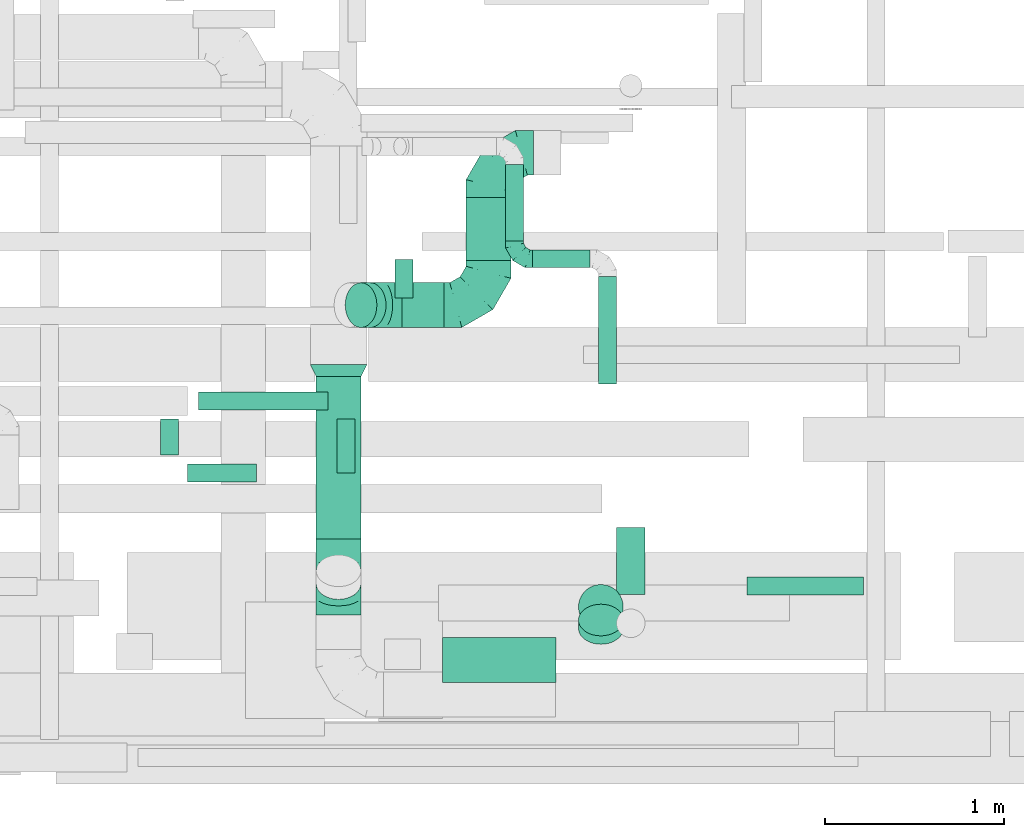
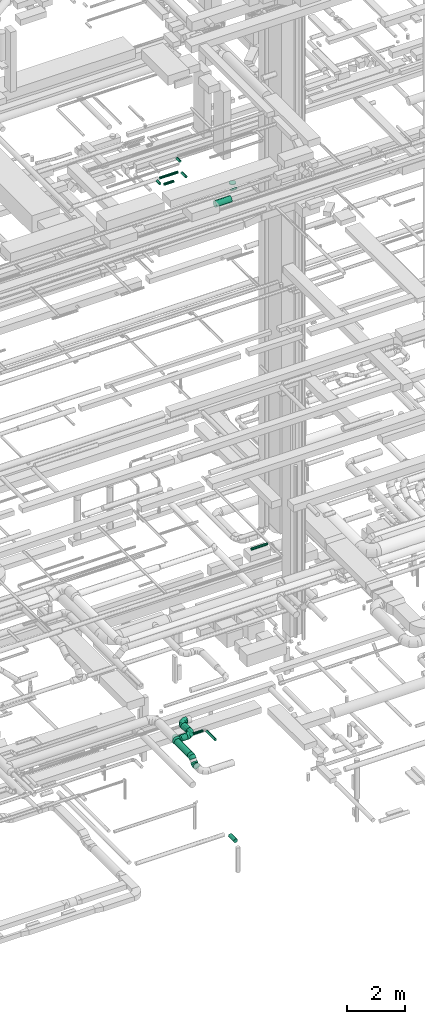
# One storey, part 123 of 337: 17 flow segments, 7 flow fittings.
"""IFC2X3 building model written with IfcOpenShell, lengths in millimetres."""

from ifc_helpers import new_model, entity, si_unit, converted_unit, derived_unit, direction, frame, origin, origin_2d_with_axis, place, context, subcontext, project, spatial, circle, extrude, faceted_brep, source, transform, mapped, material, type_object, type_shapes, element, save


model = new_model("IFC2X3")

# Units and contexts
model_context = context("Model", 3, precision=0.01, world=origin(), true_north=direction((6.12303176911189e-17, 1.0)))
body_context = subcontext(model_context, "Body", "Model", "MODEL_VIEW")
ifc_project = project(units=[si_unit("LENGTHUNIT", "METRE", prefix="MILLI"), si_unit("AREAUNIT", "SQUARE_METRE"), si_unit("VOLUMEUNIT", "CUBIC_METRE"), converted_unit("PLANEANGLEUNIT", "DEGREE", entity("IfcRatioMeasure", 0.0174532925199433), si_unit("PLANEANGLEUNIT", "RADIAN"), dimensions=[0, 0, 0, 0, 0, 0, 0]), si_unit("MASSUNIT", "GRAM", prefix="KILO"), derived_unit("MASSDENSITYUNIT", [(si_unit("MASSUNIT", "GRAM", prefix="KILO"), 1), (si_unit("LENGTHUNIT", "METRE"), -3)]), derived_unit("MOMENTOFINERTIAUNIT", [(si_unit("LENGTHUNIT", "METRE"), 4)]), si_unit("TIMEUNIT", "SECOND"), si_unit("FREQUENCYUNIT", "HERTZ"), si_unit("THERMODYNAMICTEMPERATUREUNIT", "DEGREE_CELSIUS"), derived_unit("THERMALTRANSMITTANCEUNIT", [(si_unit("MASSUNIT", "GRAM", prefix="KILO"), 1), (si_unit("THERMODYNAMICTEMPERATUREUNIT", "KELVIN"), -1), (si_unit("TIMEUNIT", "SECOND"), -3)]), derived_unit("VOLUMETRICFLOWRATEUNIT", [(si_unit("LENGTHUNIT", "METRE"), 3), (si_unit("TIMEUNIT", "SECOND"), -1)]), derived_unit("MASSFLOWRATEUNIT", [(si_unit("MASSUNIT", "GRAM", prefix="KILO"), 1), (si_unit("TIMEUNIT", "SECOND"), -1)]), derived_unit("ROTATIONALFREQUENCYUNIT", [(si_unit("TIMEUNIT", "SECOND"), -1)]), si_unit("ELECTRICCURRENTUNIT", "AMPERE"), si_unit("ELECTRICVOLTAGEUNIT", "VOLT"), si_unit("POWERUNIT", "WATT"), si_unit("FORCEUNIT", "NEWTON", prefix="KILO"), si_unit("ILLUMINANCEUNIT", "LUX"), si_unit("LUMINOUSFLUXUNIT", "LUMEN"), si_unit("LUMINOUSINTENSITYUNIT", "CANDELA"), derived_unit("USERDEFINED", [(si_unit("MASSUNIT", "GRAM", prefix="KILO"), -1), (si_unit("LENGTHUNIT", "METRE"), -2), (si_unit("TIMEUNIT", "SECOND"), 3), (si_unit("LUMINOUSFLUXUNIT", "LUMEN"), 1)]), derived_unit("LINEARVELOCITYUNIT", [(si_unit("LENGTHUNIT", "METRE"), 1), (si_unit("TIMEUNIT", "SECOND"), -1)]), si_unit("PRESSUREUNIT", "PASCAL"), derived_unit("USERDEFINED", [(si_unit("LENGTHUNIT", "METRE"), -2), (si_unit("MASSUNIT", "GRAM", prefix="KILO"), 1), (si_unit("TIMEUNIT", "SECOND"), -2)]), derived_unit("LINEARFORCEUNIT", [(si_unit("MASSUNIT", "GRAM", prefix="KILO"), 1), (si_unit("LENGTHUNIT", "METRE"), 1), (si_unit("TIMEUNIT", "SECOND"), -2), (si_unit("LENGTHUNIT", "METRE"), -1)]), derived_unit("PLANARFORCEUNIT", [(si_unit("MASSUNIT", "GRAM", prefix="KILO"), 1), (si_unit("LENGTHUNIT", "METRE"), 1), (si_unit("TIMEUNIT", "SECOND"), -2), (si_unit("LENGTHUNIT", "METRE"), -2)])], contexts=[model_context])

# Site, building, storey
site_placement = place(None, origin())
site = spatial("IfcSite", under=ifc_project, at=site_placement, CompositionType="ELEMENT")
building_placement = place(site_placement, origin())
building = spatial("IfcBuilding", under=site, at=building_placement, CompositionType="ELEMENT")
storey_placement = place(building_placement, origin())
storey = spatial("IfcBuildingStorey", under=building, at=storey_placement, CompositionType="ELEMENT", Elevation=0.0)

# Flow segments
duct_segment_type = type_object("IfcDuctSegmentType", PredefinedType="NOTDEFINED")
flow_segment_1_placement = place(storey_placement, frame((37082.67, 1408.64, -681.6)))
element("IfcFlowSegment", 1, at=flow_segment_1_placement, inside=storey, type_object=duct_segment_type, context=body_context, shape_type="SweptSolid", body=[
    extrude(circle(Radius=80.0, at=origin_2d_with_axis()), frame((81.6, 0.0, 81.6), z_axis=(0.0, 1.0, 0.0), x_axis=(-1.0, 0.0, 0.0)), (0.0, 0.0, 1.0), 375.627069999998),
])
flow_segment_2_placement = place(storey_placement, frame((37812.77, 1406.28, 11418.4)))
element("IfcFlowSegment", 2, at=flow_segment_2_placement, inside=storey, type_object=duct_segment_type, context=body_context, shape_type="SweptSolid", body=[
    extrude(circle(Radius=50.0, at=origin_2d_with_axis()), frame((0.0, 51.6, 51.6), z_axis=(1.0, 0.0, 0.0), x_axis=(0.0, 1.0, 0.0)), (0.0, 0.0, 1.0), 649.999999999982),
])
flow_segment_3_placement = place(storey_placement, frame((35406.66, 1718.56, 3290.9)))
element("IfcFlowSegment", 3, at=flow_segment_3_placement, inside=storey, type_object=duct_segment_type, context=body_context, shape_type="SweptSolid", body=[
    extrude(circle(Radius=125.0, at=origin_2d_with_axis()), frame((126.6, 0.0, 126.6), z_axis=(0.0, 1.0, 0.0), x_axis=(1.0, 0.0, 0.0)), (0.0, 0.0, 1.0), 908.226588789916),
])
flow_segment_4_placement = place(storey_placement, frame((36244.07, 3274.61, 3073.4)))
element("IfcFlowSegment", 4, at=flow_segment_4_placement, inside=storey, type_object=duct_segment_type, context=body_context, shape_type="SweptSolid", body=[
    extrude(circle(Radius=125.0, at=origin_2d_with_axis()), frame((126.6, 0.0, 126.6), z_axis=(0.0, 1.0, 0.0), x_axis=(1.0, 0.0, 0.0)), (0.0, 0.0, 1.0), 350.000000000023),
])
flow_segment_5_placement = place(storey_placement, frame((35886.72, 2898.01, 3073.4)))
element("IfcFlowSegment", 5, at=flow_segment_5_placement, inside=storey, type_object=duct_segment_type, context=body_context, shape_type="SweptSolid", body=[
    extrude(circle(Radius=125.0, at=origin_2d_with_axis()), frame((0.0, 126.6, 126.6), z_axis=(1.0, 0.0, 0.0), x_axis=(0.0, 1.0, 0.0)), (0.0, 0.0, 1.0), 233.946609406771),
])
flow_segment_6_placement = place(storey_placement, frame((35568.74, 2898.01, 3183.24)))
element("IfcFlowSegment", 6, at=flow_segment_6_placement, inside=storey, type_object=duct_segment_type, context=body_context, shape_type="SweptSolid", body=[
    extrude(circle(Radius=125.0, at=origin_2d_with_axis()), frame((141.2, 126.6, 89.98), z_axis=(-0.707106781186511, 0.0, 0.707106781186584), x_axis=(0.0, -1.0, 0.0)), (0.0, 0.0, 1.0), 72.4322018853767),
])
flow_segment_7_placement = place(storey_placement, frame((36463.89, 3383.31, 2948.4)))
element("IfcFlowSegment", 7, at=flow_segment_7_placement, inside=storey, type_object=duct_segment_type, context=body_context, shape_type="SweptSolid", body=[
    extrude(circle(Radius=50.0, at=origin_2d_with_axis()), frame((51.6, 0.0, 51.6), z_axis=(0.0, 1.0, 0.0), x_axis=(-1.0, 0.0, 0.0)), (0.0, 0.0, 1.0), 426.250000000013),
])
flow_segment_8_placement = place(storey_placement, frame((36615.48, 3231.71, 2948.4)))
element("IfcFlowSegment", 8, at=flow_segment_8_placement, inside=storey, type_object=duct_segment_type, context=body_context, shape_type="SweptSolid", body=[
    extrude(circle(Radius=50.0, at=origin_2d_with_axis()), frame((0.0, 51.6, 51.6), z_axis=(1.0, 0.0, 0.0), x_axis=(0.0, -1.0, 0.0)), (0.0, 0.0, 1.0), 320.000000000001),
])
flow_segment_9_placement = place(storey_placement, frame((36983.89, 2583.31, 2948.4)))
element("IfcFlowSegment", 9, at=flow_segment_9_placement, inside=storey, type_object=duct_segment_type, context=body_context, shape_type="SweptSolid", body=[
    extrude(circle(Radius=50.0, at=origin_2d_with_axis()), frame((51.6, 0.0, 51.6), z_axis=(0.0, 1.0, 0.0), x_axis=(-1.0, 0.0, 0.0)), (0.0, 0.0, 1.0), 599.999999999995),
])
flow_segment_10_placement = place(storey_placement, frame((35846.88, 3065.24, 27498.4)))
element("IfcFlowSegment", 10, at=flow_segment_10_placement, inside=storey, type_object=duct_segment_type, context=body_context, shape_type="SweptSolid", body=[
    extrude(circle(Radius=50.0, at=origin_2d_with_axis()), frame((51.6, 0.0, 51.6), z_axis=(0.0, 1.0, 0.0), x_axis=(-1.0, 0.0, 0.0)), (0.0, 0.0, 1.0), 214.999999999988),
])
flow_segment_11_placement = place(storey_placement, frame((35523.91, 2087.55, 27548.4)))
element("IfcFlowSegment", 11, at=flow_segment_11_placement, inside=storey, type_object=duct_segment_type, context=body_context, shape_type="SweptSolid", body=[
    extrude(circle(Radius=50.0, at=origin_2d_with_axis()), frame((51.6, 0.0, 51.6), z_axis=(0.0, 1.0, 0.0), x_axis=(-1.0, 0.0, 0.0)), (0.0, 0.0, 1.0), 301.519488620757),
])
flow_segment_12_placement = place(storey_placement, frame((34538.3, 2187.55, 27548.4)))
element("IfcFlowSegment", 12, at=flow_segment_12_placement, inside=storey, type_object=duct_segment_type, context=body_context, shape_type="SweptSolid", body=[
    extrude(circle(Radius=50.0, at=origin_2d_with_axis()), frame((51.6, 0.0, 51.6), z_axis=(0.0, 1.0, 0.0), x_axis=(1.0, 0.0, 0.0)), (0.0, 0.0, 1.0), 201.519488620777),
])
flow_segment_13_placement = place(storey_placement, frame((34689.9, 2035.95, 27548.4)))
element("IfcFlowSegment", 13, at=flow_segment_13_placement, inside=storey, type_object=duct_segment_type, context=body_context, shape_type="SweptSolid", body=[
    extrude(circle(Radius=50.0, at=origin_2d_with_axis()), frame((0.0, 51.6, 51.6), z_axis=(1.0, 0.0, 0.0), x_axis=(0.0, -1.0, 0.0)), (0.0, 0.0, 1.0), 386.249999999973),
])
flow_segment_14_placement = place(storey_placement, frame((34750.5, 2437.47, 27548.4)))
element("IfcFlowSegment", 14, at=flow_segment_14_placement, inside=storey, type_object=duct_segment_type, context=body_context, shape_type="SweptSolid", body=[
    extrude(circle(Radius=50.0, at=origin_2d_with_axis()), frame((0.0, 51.6, 51.6), z_axis=(1.0, 0.0, 0.0), x_axis=(0.0, -1.0, 0.0)), (0.0, 0.0, 1.0), 725.0),
])
flow_segment_15_placement = place(storey_placement, frame((36114.8, 916.58, 26773.4)))
element("IfcFlowSegment", 15, at=flow_segment_15_placement, inside=storey, type_object=duct_segment_type, context=body_context, shape_type="SweptSolid", body=[
    extrude(circle(Radius=125.0, at=origin_2d_with_axis()), frame((0.0, 126.6, 126.6), z_axis=(1.0, 0.0, 0.0), x_axis=(0.0, -1.0, 0.0)), (0.0, 0.0, 1.0), 632.499999999999),
])
flow_segment_16_placement = place(storey_placement, frame((36870.71, 1129.97, 26986.79)))
element("IfcFlowSegment", 16, at=flow_segment_16_placement, inside=storey, type_object=duct_segment_type, context=body_context, shape_type="SweptSolid", body=[
    extrude(circle(Radius=125.0, at=origin_2d_with_axis()), frame((126.6, 89.98, 89.98), z_axis=(0.0, 0.707106781186545, 0.70710678118655), x_axis=(1.0, 0.0, 0.0)), (0.0, 0.0, 1.0), 66.4466094067439),
])
flow_segment_17_placement = place(storey_placement, frame((36870.71, 1213.56, 27300.54)))
element("IfcFlowSegment", 17, at=flow_segment_17_placement, inside=storey, type_object=duct_segment_type, context=body_context, shape_type="SweptSolid", body=[
    extrude(circle(Radius=125.0, at=origin_2d_with_axis()), frame((126.6, 126.6, 0.0), z_axis=(0.0, 0.0, 1.0), x_axis=(0.0, 1.0, 0.0)), (0.0, 0.0, 1.0), 29.4617613084081),
])

# Flow fittings
ifc_material = material()
duct_fitting_type_1 = type_object("IfcDuctFittingType", PredefinedType="NOTDEFINED", material=ifc_material)
shared_shape_1 = source(origin(), body_context, "Body", "Brep", [
    faceted_brep([(-100.0, 0.0, -50.0), (-100.0, -12.94, -48.3), (-100.0, -25.0, -43.3), (-100.0, -35.36, -35.36), (-100.0, -43.3, -25.0), (-100.0, -48.3, -12.94), (-100.0, -50.0, 0.0), (-100.0, -48.3, 12.94), (-100.0, -43.3, 25.0), (-100.0, -35.36, 35.36), (-100.0, -25.0, 43.3), (-100.0, -12.94, 48.3), (-100.0, 0.0, 50.0), (-100.0, 12.94, 48.3), (-100.0, 25.0, 43.3), (-100.0, 35.36, 35.36), (-100.0, 43.3, 25.0), (-100.0, 48.3, 12.94), (-100.0, 50.0, 0.0), (-100.0, 48.3, -12.94), (-100.0, 43.3, -25.0), (-100.0, 35.36, -35.36), (-100.0, 25.0, -43.3), (-100.0, 12.94, -48.3), (-76.67, 12.94, 48.3), (-79.9, 25.0, 43.3), (-73.21, 0.0, 50.0), (-82.68, 35.36, 35.36), (-86.15, 48.3, 12.94), (-86.6, 50.0, 0.0), (-84.81, 43.3, 25.0), (-84.81, 43.3, -25.0), (-82.68, 35.36, -35.36), (-86.15, 48.3, -12.94), (-76.67, 12.94, -48.3), (-73.21, 0.0, -50.0), (-79.9, 25.0, -43.3), (-69.74, -12.94, -48.3), (-66.51, -25.0, -43.3), (-63.73, -35.36, -35.36), (-61.6, -43.3, -25.0), (-60.26, -48.3, -12.94), (-59.81, -50.0, 0.0), (-60.26, -48.3, 12.94), (-61.6, -43.3, 25.0), (-63.73, -35.36, 35.36), (-66.51, -25.0, 43.3), (-69.74, -12.94, 48.3), (-36.27, 36.27, 48.3), (-45.1, 45.1, 43.3), (-26.79, 26.79, 50.0), (-52.68, 52.68, 35.36), (-58.49, 58.49, 25.0), (-62.15, 62.15, 12.94), (-63.4, 63.4, 0.0), (-62.15, 62.15, -12.94), (-58.49, 58.49, -25.0), (-52.68, 52.68, -35.36), (-36.27, 36.27, -48.3), (-26.79, 26.79, -50.0), (-45.1, 45.1, -43.3), (-17.32, 17.32, -48.3), (-8.49, 8.49, -43.3), (-0.91, 0.91, -35.36), (4.9, -4.9, -25.0), (8.56, -8.56, -12.94), (9.81, -9.81, 0.0), (8.56, -8.56, 12.94), (4.9, -4.9, 25.0), (-0.91, 0.91, 35.36), (-8.49, 8.49, 43.3), (-17.32, 17.32, 48.3), (-12.94, 76.67, 48.3), (-25.0, 79.9, 43.3), (0.0, 73.21, 50.0), (-35.36, 82.68, 35.36), (-43.3, 84.81, 25.0), (-48.3, 86.15, 12.94), (-50.0, 86.6, 0.0), (-48.3, 86.15, -12.94), (-43.3, 84.81, -25.0), (-35.36, 82.68, -35.36), (-12.94, 76.67, -48.3), (0.0, 73.21, -50.0), (-25.0, 79.9, -43.3), (12.94, 69.74, -48.3), (25.0, 66.51, -43.3), (35.36, 63.73, -35.36), (43.3, 61.6, -25.0), (48.3, 60.26, -12.94), (50.0, 59.81, 0.0), (48.3, 60.26, 12.94), (43.3, 61.6, 25.0), (35.36, 63.73, 35.36), (25.0, 66.51, 43.3), (12.94, 69.74, 48.3), (-12.94, 100.0, -48.3), (-25.0, 100.0, -43.3), (-35.36, 100.0, -35.36), (-43.3, 100.0, -25.0), (-48.3, 100.0, -12.94), (-50.0, 100.0, 0.0), (-48.3, 100.0, 12.94), (-43.3, 100.0, 25.0), (-35.36, 100.0, 35.36), (-25.0, 100.0, 43.3), (-12.94, 100.0, 48.3), (0.0, 100.0, 50.0), (12.94, 100.0, 48.3), (25.0, 100.0, 43.3), (35.36, 100.0, 35.36), (43.3, 100.0, 25.0), (48.3, 100.0, 12.94), (50.0, 100.0, 0.0), (48.3, 100.0, -12.94), (43.3, 100.0, -25.0), (35.36, 100.0, -35.36), (25.0, 100.0, -43.3), (12.94, 100.0, -48.3), (0.0, 100.0, -50.0)], [[[0, 1, 2, 3, 4, 5, 6, 7, 8, 9, 10, 11, 12, 13, 14, 15, 16, 17, 18, 19, 20, 21, 22, 23]], [[24, 25, 14, 13]], [[26, 24, 13, 12]], [[14, 25, 27, 15]], [[28, 29, 18, 17]], [[30, 28, 17, 16]], [[15, 27, 30, 16]], [[20, 31, 32, 21]], [[33, 31, 20, 19]], [[18, 29, 33, 19]], [[34, 35, 0, 23]], [[36, 34, 23, 22]], [[32, 36, 22, 21]], [[2, 1, 37, 38]], [[3, 2, 38, 39]], [[0, 35, 37, 1]], [[5, 4, 40, 41]], [[6, 5, 41, 42]], [[3, 39, 40, 4]], [[6, 42, 43, 7]], [[7, 43, 44, 8]], [[8, 44, 45, 9]], [[10, 46, 47, 11]], [[11, 47, 26, 12]], [[10, 9, 45, 46]], [[48, 49, 25, 24]], [[50, 48, 24, 26]], [[27, 25, 49, 51]], [[52, 53, 28, 30]], [[51, 52, 30, 27]], [[29, 28, 53, 54]], [[55, 56, 31, 33]], [[54, 55, 33, 29]], [[57, 32, 31, 56]], [[58, 59, 35, 34]], [[60, 58, 34, 36]], [[57, 60, 36, 32]], [[37, 35, 59, 61]], [[38, 37, 61, 62]], [[39, 38, 62, 63]], [[41, 40, 64, 65]], [[42, 41, 65, 66]], [[63, 64, 40, 39]], [[43, 42, 66, 67]], [[44, 43, 67, 68]], [[68, 69, 45, 44]], [[46, 45, 69, 70]], [[47, 46, 70, 71]], [[26, 47, 71, 50]], [[72, 73, 49, 48]], [[74, 72, 48, 50]], [[51, 49, 73, 75]], [[76, 77, 53, 52]], [[75, 76, 52, 51]], [[54, 53, 77, 78]], [[79, 80, 56, 55]], [[78, 79, 55, 54]], [[81, 57, 56, 80]], [[82, 83, 59, 58]], [[84, 82, 58, 60]], [[81, 84, 60, 57]], [[61, 59, 83, 85]], [[62, 61, 85, 86]], [[63, 62, 86, 87]], [[65, 64, 88, 89]], [[66, 65, 89, 90]], [[87, 88, 64, 63]], [[67, 66, 90, 91]], [[68, 67, 91, 92]], [[92, 93, 69, 68]], [[70, 69, 93, 94]], [[71, 70, 94, 95]], [[50, 71, 95, 74]], [[96, 97, 98, 99, 100, 101, 102, 103, 104, 105, 106, 107, 108, 109, 110, 111, 112, 113, 114, 115, 116, 117, 118, 119]], [[72, 74, 107, 106]], [[73, 72, 106, 105]], [[75, 73, 105, 104]], [[77, 76, 103, 102]], [[78, 77, 102, 101]], [[75, 104, 103, 76]], [[78, 101, 100, 79]], [[79, 100, 99, 80]], [[80, 99, 98, 81]], [[96, 119, 83, 82]], [[97, 96, 82, 84]], [[84, 81, 98, 97]], [[83, 119, 118, 85]], [[85, 118, 117, 86]], [[86, 117, 116, 87]], [[88, 115, 114, 89]], [[89, 114, 113, 90]], [[87, 116, 115, 88]], [[91, 90, 113, 112]], [[92, 91, 112, 111]], [[93, 92, 111, 110]], [[95, 94, 109, 108]], [[74, 95, 108, 107]], [[110, 109, 94, 93]]]),
])
type_shapes(duct_fitting_type_1, [shared_shape_1])
flow_fitting_1_placement = place(storey_placement, frame((36515.48, 3283.31, 3000.0), z_axis=(0.0, 0.0, 1.0), x_axis=(0.0, -1.0, 0.0)))
element("IfcFlowFitting", 18, at=flow_fitting_1_placement, inside=storey, type_object=duct_fitting_type_1, material=ifc_material, context=body_context, shape_type="MappedRepresentation", body=[
    mapped(shared_shape_1, transform((0.0, 0.0, 0.0), scale=1.0)),
])
duct_fitting_type_2 = type_object("IfcDuctFittingType", PredefinedType="NOTDEFINED", material=ifc_material)
shared_shape_2 = source(origin(), body_context, "Body", "Brep", [
    faceted_brep([(-250.0, 0.0, -125.0), (-250.0, -32.35, -120.74), (-250.0, -62.5, -108.25), (-250.0, -88.39, -88.39), (-250.0, -108.25, -62.5), (-250.0, -120.74, -32.35), (-250.0, -125.0, 0.0), (-250.0, -120.74, 32.35), (-250.0, -108.25, 62.5), (-250.0, -88.39, 88.39), (-250.0, -62.5, 108.25), (-250.0, -32.35, 120.74), (-250.0, 0.0, 125.0), (-250.0, 32.35, 120.74), (-250.0, 62.5, 108.25), (-250.0, 88.39, 88.39), (-250.0, 108.25, 62.5), (-250.0, 120.74, 32.35), (-250.0, 125.0, 0.0), (-250.0, 120.74, -32.35), (-250.0, 108.25, -62.5), (-250.0, 88.39, -88.39), (-250.0, 62.5, -108.25), (-250.0, 32.35, -120.74), (-191.68, 32.35, 120.74), (-199.76, 62.5, 108.25), (-183.01, 0.0, 125.0), (-206.7, 88.39, 88.39), (-215.37, 120.74, 32.35), (-216.51, 125.0, 0.0), (-212.02, 108.25, 62.5), (-212.02, 108.25, -62.5), (-206.7, 88.39, -88.39), (-215.37, 120.74, -32.35), (-191.68, 32.35, -120.74), (-183.01, 0.0, -125.0), (-199.76, 62.5, -108.25), (-174.34, -32.35, -120.74), (-166.27, -62.5, -108.25), (-159.33, -88.39, -88.39), (-154.01, -108.25, -62.5), (-150.66, -120.74, -32.35), (-149.52, -125.0, 0.0), (-150.66, -120.74, 32.35), (-154.01, -108.25, 62.5), (-159.33, -88.39, 88.39), (-166.27, -62.5, 108.25), (-174.34, -32.35, 120.74), (-90.67, 90.67, 120.74), (-112.74, 112.74, 108.25), (-66.99, 66.99, 125.0), (-131.69, 131.69, 88.39), (-146.23, 146.23, 62.5), (-155.38, 155.38, 32.35), (-158.49, 158.49, 0.0), (-155.38, 155.38, -32.35), (-146.23, 146.23, -62.5), (-131.69, 131.69, -88.39), (-90.67, 90.67, -120.74), (-66.99, 66.99, -125.0), (-112.74, 112.74, -108.25), (-43.3, 43.3, -120.74), (-21.23, 21.23, -108.25), (-2.28, 2.28, -88.39), (12.26, -12.26, -62.5), (21.4, -21.4, -32.35), (24.52, -24.52, 0.0), (21.4, -21.4, 32.35), (12.26, -12.26, 62.5), (-2.28, 2.28, 88.39), (-21.23, 21.23, 108.25), (-43.3, 43.3, 120.74), (-32.35, 191.68, 120.74), (-62.5, 199.76, 108.25), (0.0, 183.01, 125.0), (-88.39, 206.7, 88.39), (-108.25, 212.02, 62.5), (-120.74, 215.37, 32.35), (-125.0, 216.51, 0.0), (-120.74, 215.37, -32.35), (-108.25, 212.02, -62.5), (-88.39, 206.7, -88.39), (-32.35, 191.68, -120.74), (0.0, 183.01, -125.0), (-62.5, 199.76, -108.25), (32.35, 174.34, -120.74), (62.5, 166.27, -108.25), (88.39, 159.33, -88.39), (108.25, 154.01, -62.5), (120.74, 150.66, -32.35), (125.0, 149.52, 0.0), (120.74, 150.66, 32.35), (108.25, 154.01, 62.5), (88.39, 159.33, 88.39), (62.5, 166.27, 108.25), (32.35, 174.34, 120.74), (-32.35, 250.0, -120.74), (-62.5, 250.0, -108.25), (-88.39, 250.0, -88.39), (-108.25, 250.0, -62.5), (-120.74, 250.0, -32.35), (-125.0, 250.0, 0.0), (-120.74, 250.0, 32.35), (-108.25, 250.0, 62.5), (-88.39, 250.0, 88.39), (-62.5, 250.0, 108.25), (-32.35, 250.0, 120.74), (0.0, 250.0, 125.0), (32.35, 250.0, 120.74), (62.5, 250.0, 108.25), (88.39, 250.0, 88.39), (108.25, 250.0, 62.5), (120.74, 250.0, 32.35), (125.0, 250.0, 0.0), (120.74, 250.0, -32.35), (108.25, 250.0, -62.5), (88.39, 250.0, -88.39), (62.5, 250.0, -108.25), (32.35, 250.0, -120.74), (0.0, 250.0, -125.0)], [[[0, 1, 2, 3, 4, 5, 6, 7, 8, 9, 10, 11, 12, 13, 14, 15, 16, 17, 18, 19, 20, 21, 22, 23]], [[24, 25, 14, 13]], [[26, 24, 13, 12]], [[14, 25, 27, 15]], [[28, 29, 18, 17]], [[30, 28, 17, 16]], [[15, 27, 30, 16]], [[20, 31, 32, 21]], [[33, 31, 20, 19]], [[18, 29, 33, 19]], [[34, 35, 0, 23]], [[36, 34, 23, 22]], [[21, 32, 36, 22]], [[1, 0, 35, 37]], [[2, 1, 37, 38]], [[38, 39, 3, 2]], [[5, 4, 40, 41]], [[6, 5, 41, 42]], [[39, 40, 4, 3]], [[6, 42, 43, 7]], [[7, 43, 44, 8]], [[8, 44, 45, 9]], [[9, 45, 46, 10]], [[10, 46, 47, 11]], [[26, 12, 11, 47]], [[48, 49, 25, 24]], [[50, 48, 24, 26]], [[27, 25, 49, 51]], [[52, 53, 28, 30]], [[51, 52, 30, 27]], [[29, 28, 53, 54]], [[55, 56, 31, 33]], [[54, 55, 33, 29]], [[32, 31, 56, 57]], [[58, 59, 35, 34]], [[60, 58, 34, 36]], [[57, 60, 36, 32]], [[37, 35, 59, 61]], [[38, 37, 61, 62]], [[39, 38, 62, 63]], [[41, 40, 64, 65]], [[42, 41, 65, 66]], [[63, 64, 40, 39]], [[43, 42, 66, 67]], [[44, 43, 67, 68]], [[68, 69, 45, 44]], [[46, 45, 69, 70]], [[47, 46, 70, 71]], [[26, 47, 71, 50]], [[72, 73, 49, 48]], [[74, 72, 48, 50]], [[51, 49, 73, 75]], [[76, 77, 53, 52]], [[75, 76, 52, 51]], [[54, 53, 77, 78]], [[79, 80, 56, 55]], [[78, 79, 55, 54]], [[57, 56, 80, 81]], [[82, 83, 59, 58]], [[84, 82, 58, 60]], [[81, 84, 60, 57]], [[61, 59, 83, 85]], [[62, 61, 85, 86]], [[63, 62, 86, 87]], [[65, 64, 88, 89]], [[66, 65, 89, 90]], [[87, 88, 64, 63]], [[67, 66, 90, 91]], [[68, 67, 91, 92]], [[92, 93, 69, 68]], [[70, 69, 93, 94]], [[71, 70, 94, 95]], [[50, 71, 95, 74]], [[96, 97, 98, 99, 100, 101, 102, 103, 104, 105, 106, 107, 108, 109, 110, 111, 112, 113, 114, 115, 116, 117, 118, 119]], [[72, 74, 107, 106]], [[73, 72, 106, 105]], [[75, 73, 105, 104]], [[77, 76, 103, 102]], [[78, 77, 102, 101]], [[75, 104, 103, 76]], [[78, 101, 100, 79]], [[79, 100, 99, 80]], [[80, 99, 98, 81]], [[84, 97, 96, 82]], [[82, 96, 119, 83]], [[84, 81, 98, 97]], [[83, 119, 118, 85]], [[85, 118, 117, 86]], [[116, 87, 86, 117]], [[88, 115, 114, 89]], [[89, 114, 113, 90]], [[115, 88, 87, 116]], [[91, 90, 113, 112]], [[92, 91, 112, 111]], [[111, 110, 93, 92]], [[95, 94, 109, 108]], [[74, 95, 108, 107]], [[110, 109, 94, 93]]]),
])
type_shapes(duct_fitting_type_2, [shared_shape_2])
flow_fitting_2_placement = place(storey_placement, frame((36370.66, 3874.61, 3200.0), z_axis=(0.0, 0.0, 1.0), x_axis=(-1.0, 0.0, 0.0)))
element("IfcFlowFitting", 19, at=flow_fitting_2_placement, inside=storey, type_object=duct_fitting_type_2, material=ifc_material, context=body_context, shape_type="MappedRepresentation", body=[
    mapped(shared_shape_2, transform((0.0, 0.0, 0.0), scale=1.0)),
])
flow_fitting_3_placement = place(storey_placement, frame((36370.66, 3024.61, 3200.0)))
element("IfcFlowFitting", 20, at=flow_fitting_3_placement, inside=storey, type_object=duct_fitting_type_2, material=ifc_material, context=body_context, shape_type="MappedRepresentation", body=[
    mapped(shared_shape_2, transform((0.0, 0.0, 0.0), scale=1.0)),
])
duct_fitting_type_3 = type_object("IfcDuctFittingType", PredefinedType="NOTDEFINED", material=ifc_material)
shared_shape_3 = source(origin(), body_context, "Body", "Brep", [
    faceted_brep([(-103.55, 0.0, -125.0), (-103.55, -32.35, -120.74), (-103.55, -62.5, -108.25), (-103.55, -88.39, -88.39), (-103.55, -108.25, -62.5), (-103.55, -120.74, -32.35), (-103.55, -125.0, 0.0), (-103.55, -120.74, 32.35), (-103.55, -108.25, 62.5), (-103.55, -88.39, 88.39), (-103.55, -62.5, 108.25), (-103.55, -32.35, 120.74), (-103.55, 0.0, 125.0), (-103.55, 32.35, 120.74), (-103.55, 62.5, 108.25), (-103.55, 88.39, 88.39), (-103.55, 108.25, 62.5), (-103.55, 120.74, 32.35), (-103.55, 125.0, 0.0), (-103.55, 120.74, -32.35), (-103.55, 108.25, -62.5), (-103.55, 88.39, -88.39), (-103.55, 62.5, -108.25), (-103.55, 32.35, -120.74), (-13.4, 32.35, 120.74), (-25.89, 62.5, 108.25), (0.0, 0.0, 125.0), (-36.61, 88.39, 88.39), (-44.84, 108.25, 62.5), (-50.01, 120.74, 32.35), (-51.78, 125.0, 0.0), (-50.01, 120.74, -32.35), (-44.84, 108.25, -62.5), (-36.61, 88.39, -88.39), (-13.4, 32.35, -120.74), (0.0, 0.0, -125.0), (-25.89, 62.5, -108.25), (13.4, -32.35, -120.74), (25.89, -62.5, -108.25), (36.61, -88.39, -88.39), (44.84, -108.25, -62.5), (50.01, -120.74, -32.35), (51.78, -125.0, 0.0), (50.01, -120.74, 32.35), (44.84, -108.25, 62.5), (36.61, -88.39, 88.39), (25.89, -62.5, 108.25), (13.4, -32.35, 120.74), (73.22, 73.22, 125.0), (50.35, 96.1, 120.74), (29.03, 117.42, 108.25), (10.72, 135.72, 88.39), (-3.32, 149.77, 62.5), (-12.15, 158.6, 32.35), (-15.17, 161.61, 0.0), (-12.15, 158.6, -32.35), (-3.32, 149.77, -62.5), (10.72, 135.72, -88.39), (29.03, 117.42, -108.25), (50.35, 96.1, -120.74), (73.22, 73.22, -125.0), (96.1, 50.35, -120.74), (117.42, 29.03, -108.25), (135.72, 10.72, -88.39), (149.77, -3.32, -62.5), (158.6, -12.15, -32.35), (161.61, -15.17, 0.0), (158.6, -12.15, 32.35), (149.77, -3.32, 62.5), (135.72, 10.72, 88.39), (117.42, 29.03, 108.25), (96.1, 50.35, 120.74)], [[[0, 1, 2, 3, 4, 5, 6, 7, 8, 9, 10, 11, 12, 13, 14, 15, 16, 17, 18, 19, 20, 21, 22, 23]], [[24, 25, 14, 13]], [[26, 24, 13, 12]], [[14, 25, 27, 15]], [[28, 29, 17, 16]], [[28, 16, 15, 27]], [[30, 18, 17, 29]], [[31, 32, 20, 19]], [[30, 31, 19, 18]], [[32, 33, 21, 20]], [[34, 35, 0, 23]], [[36, 34, 23, 22]], [[33, 36, 22, 21]], [[1, 0, 35, 37]], [[2, 1, 37, 38]], [[38, 39, 3, 2]], [[5, 4, 40, 41]], [[6, 5, 41, 42]], [[39, 40, 4, 3]], [[6, 42, 43, 7]], [[7, 43, 44, 8]], [[8, 44, 45, 9]], [[9, 45, 46, 10]], [[10, 46, 47, 11]], [[26, 12, 11, 47]], [[24, 26, 48, 49]], [[25, 24, 49, 50]], [[27, 25, 50, 51]], [[29, 28, 52, 53]], [[30, 29, 53, 54]], [[51, 52, 28, 27]], [[30, 54, 55, 31]], [[31, 55, 56, 32]], [[57, 33, 32, 56]], [[36, 58, 59, 34]], [[34, 59, 60, 35]], [[58, 36, 33, 57]], [[35, 60, 61, 37]], [[37, 61, 62, 38]], [[63, 39, 38, 62]], [[40, 64, 65, 41]], [[41, 65, 66, 42]], [[64, 40, 39, 63]], [[43, 42, 66, 67]], [[44, 43, 67, 68]], [[68, 69, 45, 44]], [[47, 46, 70, 71]], [[26, 47, 71, 48]], [[69, 70, 46, 45]], [[59, 58, 57, 56, 55, 54, 53, 52, 51, 50, 49, 48, 71, 70, 69, 68, 67, 66, 65, 64, 63, 62, 61, 60]]]),
])
type_shapes(duct_fitting_type_3, [shared_shape_3])
flow_fitting_4_placement = place(storey_placement, frame((35533.26, 1397.51, 3200.0), z_axis=(1.0, 0.0, 0.0), x_axis=(0.0, 1.0, 0.0)))
element("IfcFlowFitting", 21, at=flow_fitting_4_placement, inside=storey, type_object=duct_fitting_type_3, material=ifc_material, context=body_context, shape_type="MappedRepresentation", body=[
    mapped(shared_shape_3, transform((0.0, 0.0, 0.0), scale=1.0)),
])
duct_fitting_type_4 = type_object("IfcDuctFittingType", PredefinedType="NOTDEFINED", material=ifc_material)
type_shapes(duct_fitting_type_4, [shared_shape_3])
flow_fitting_5_placement = place(storey_placement, frame((35783.16, 3024.61, 3200.0), z_axis=(0.0, 1.0, 0.0), x_axis=(-1.0, 0.0, 0.0)))
element("IfcFlowFitting", 22, at=flow_fitting_5_placement, inside=storey, type_object=duct_fitting_type_4, material=ifc_material, context=body_context, shape_type="MappedRepresentation", body=[
    mapped(shared_shape_3, transform((0.0, 0.0, 0.0), scale=1.0)),
])
flow_fitting_6_placement = place(storey_placement, frame((35533.26, 1615.01, 3417.5), z_axis=(-1.0, 0.0, 0.0), x_axis=(0.0, 0.707106792500146, 0.707106769872949)))
element("IfcFlowFitting", 23, at=flow_fitting_6_placement, inside=storey, type_object=duct_fitting_type_3, material=ifc_material, context=body_context, shape_type="MappedRepresentation", body=[
    mapped(shared_shape_3, transform((0.0, 0.0, 0.0), scale=1.0)),
])
duct_fitting_type_5 = type_object("IfcDuctFittingType", PredefinedType="NOTDEFINED", material=ifc_material)
shared_shape_4 = source(origin(), body_context, "Body", "Brep", [
    faceted_brep([(65.0, -78.75, -103.9), (65.0, -40.76, -119.63), (65.0, 0.0, -125.0), (65.0, 40.76, -119.63), (65.0, 78.75, -103.9), (65.0, 111.37, -78.87), (65.0, 136.4, -46.25), (65.0, 152.13, -8.26), (65.0, 157.5, 32.5), (65.0, 152.13, 73.26), (65.0, 136.4, 111.25), (65.0, 111.37, 143.87), (65.0, 78.75, 168.9), (65.0, 40.76, 184.63), (65.0, 0.0, 190.0), (65.0, -40.76, 184.63), (65.0, -78.75, 168.9), (65.0, -111.37, 143.87), (65.0, -136.4, 111.25), (65.0, -152.13, 73.26), (65.0, -157.5, 32.5), (65.0, -152.13, -8.26), (65.0, -136.4, -46.25), (65.0, -111.37, -78.87), (0.0, 118.88, 38.63), (0.0, 125.0, 0.0), (0.0, 118.88, -38.63), (0.0, 101.13, -73.47), (0.0, 87.3, -87.3), (0.0, 73.47, -101.13), (0.0, 38.63, -118.88), (0.0, 0.0, -125.0), (0.0, -38.63, -118.88), (0.0, -73.47, -101.13), (0.0, -87.3, -87.3), (0.0, -101.13, -73.47), (0.0, -118.88, -38.63), (0.0, -125.0, 0.0), (0.0, -118.88, 38.63), (0.0, -101.13, 73.47), (0.0, -87.3, 87.3), (0.0, -73.47, 101.13), (0.0, -38.63, 118.88), (0.0, 0.0, 125.0), (0.0, 38.63, 118.88), (0.0, 73.47, 101.13), (0.0, 87.3, 87.3), (0.0, 101.13, 73.47), (27.61, 136.24, 40.37), (39.27, 144.63, 19.63), (34.87, 131.59, 71.94), (33.33, 117.38, 95.98), (39.27, 0.0, 164.27), (27.61, 26.57, 150.04), (33.33, 79.32, 134.04), (32.96, 100.04, 116.52), (34.87, 54.51, 149.03), (35.99, 142.99, 17.99), (27.61, -26.57, 150.04), (34.87, -54.51, 149.03), (33.33, -79.32, 134.04), (27.61, -136.24, 40.37), (35.99, -142.99, 17.99), (39.27, -144.63, 19.63), (33.33, -117.38, 95.98), (32.96, -100.04, 116.52), (34.87, -131.59, 71.94), (35.99, 0.0, -125.0), (27.42, -26.95, -122.36), (27.42, -136.07, -13.24), (34.87, -131.59, -37.07), (33.33, -117.38, -62.65), (34.87, -54.51, -114.16), (33.33, -79.32, -100.71), (32.96, -100.04, -83.56), (27.42, 136.07, -13.24), (27.42, 26.95, -122.36), (34.87, 54.51, -114.16), (33.33, 79.32, -100.71), (34.87, 131.59, -37.07), (33.33, 117.38, -62.65), (32.96, 100.04, -83.56)], [[[0, 1, 2, 3, 4, 5, 6, 7, 8, 9, 10, 11, 12, 13, 14, 15, 16, 17, 18, 19, 20, 21, 22, 23]], [[24, 25, 26, 27, 28, 29, 30, 31, 32, 33, 34, 35, 36, 37, 38, 39, 40, 41, 42, 43, 44, 45, 46, 47]], [[48, 9, 49]], [[47, 50, 24]], [[51, 50, 47]], [[48, 24, 50]], [[9, 8, 49]], [[24, 48, 25]], [[10, 9, 50]], [[52, 53, 43]], [[51, 10, 50]], [[45, 54, 55]], [[45, 44, 56]], [[48, 49, 57, 25]], [[13, 53, 52]], [[52, 14, 13]], [[9, 48, 50]], [[45, 56, 54]], [[53, 56, 44]], [[12, 56, 13]], [[13, 56, 53]], [[56, 12, 54]], [[43, 53, 44]], [[11, 55, 54]], [[12, 11, 54]], [[11, 10, 51]], [[47, 46, 45, 55]], [[55, 11, 51]], [[47, 55, 51]], [[58, 15, 52]], [[41, 59, 42]], [[60, 59, 41]], [[58, 42, 59]], [[15, 14, 52]], [[42, 58, 43]], [[16, 15, 59]], [[61, 37, 62, 63]], [[60, 16, 59]], [[39, 64, 65]], [[39, 38, 66]], [[43, 58, 52]], [[19, 61, 63]], [[63, 20, 19]], [[15, 58, 59]], [[39, 66, 64]], [[61, 66, 38]], [[18, 66, 19]], [[19, 66, 61]], [[66, 18, 64]], [[37, 61, 38]], [[17, 65, 64]], [[18, 17, 64]], [[17, 16, 60]], [[41, 40, 39, 65]], [[65, 17, 60]], [[41, 65, 60]], [[67, 2, 68, 31]], [[21, 69, 70]], [[71, 70, 35]], [[69, 36, 70]], [[69, 20, 63, 62, 37]], [[36, 69, 37]], [[22, 21, 70]], [[21, 20, 69]], [[71, 22, 70]], [[23, 22, 71]], [[33, 32, 72]], [[33, 73, 74]], [[35, 34, 33, 74]], [[2, 1, 68]], [[35, 70, 36]], [[33, 72, 73]], [[68, 72, 32]], [[0, 72, 1]], [[1, 72, 68]], [[0, 23, 73]], [[23, 74, 73]], [[74, 23, 71]], [[72, 0, 73]], [[31, 68, 32]], [[35, 74, 71]], [[57, 49, 8, 75, 25]], [[3, 76, 77]], [[78, 77, 29]], [[76, 30, 77]], [[2, 67, 31, 76]], [[30, 76, 31]], [[4, 3, 77]], [[3, 2, 76]], [[78, 4, 77]], [[5, 4, 78]], [[27, 26, 79]], [[27, 80, 81]], [[29, 28, 27, 81]], [[8, 7, 75]], [[29, 77, 30]], [[27, 79, 80]], [[75, 79, 26]], [[6, 79, 7]], [[7, 79, 75]], [[6, 5, 80]], [[5, 81, 80]], [[81, 5, 78]], [[79, 6, 80]], [[25, 75, 26]], [[29, 81, 78]]]),
])
type_shapes(duct_fitting_type_5, [shared_shape_4])
flow_fitting_7_placement = place(storey_placement, frame((35533.26, 2626.79, 3417.5), z_axis=(0.0, 0.0, 1.0), x_axis=(0.0, 1.0, 0.0)))
element("IfcFlowFitting", 24, at=flow_fitting_7_placement, inside=storey, type_object=duct_fitting_type_5, material=ifc_material, context=body_context, shape_type="MappedRepresentation", body=[
    mapped(shared_shape_4, transform((0.0, 0.0, 0.0), scale=1.0)),
])

save(model, "model.ifc")
